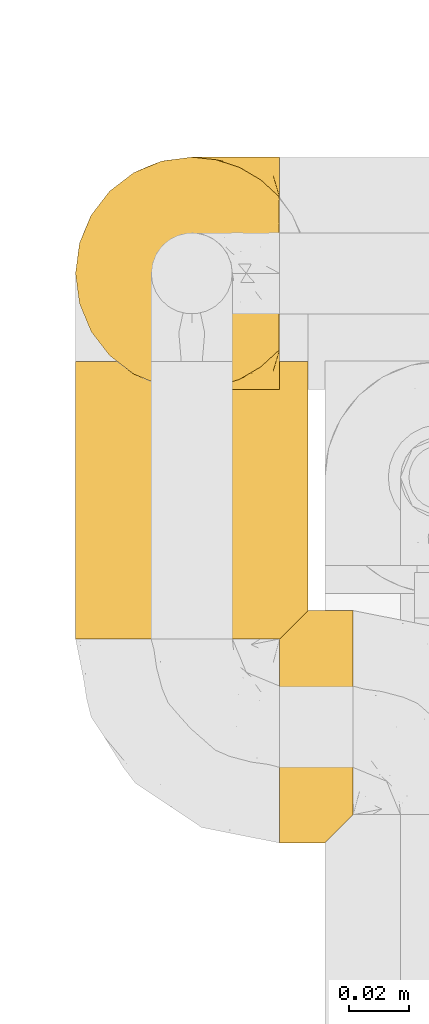
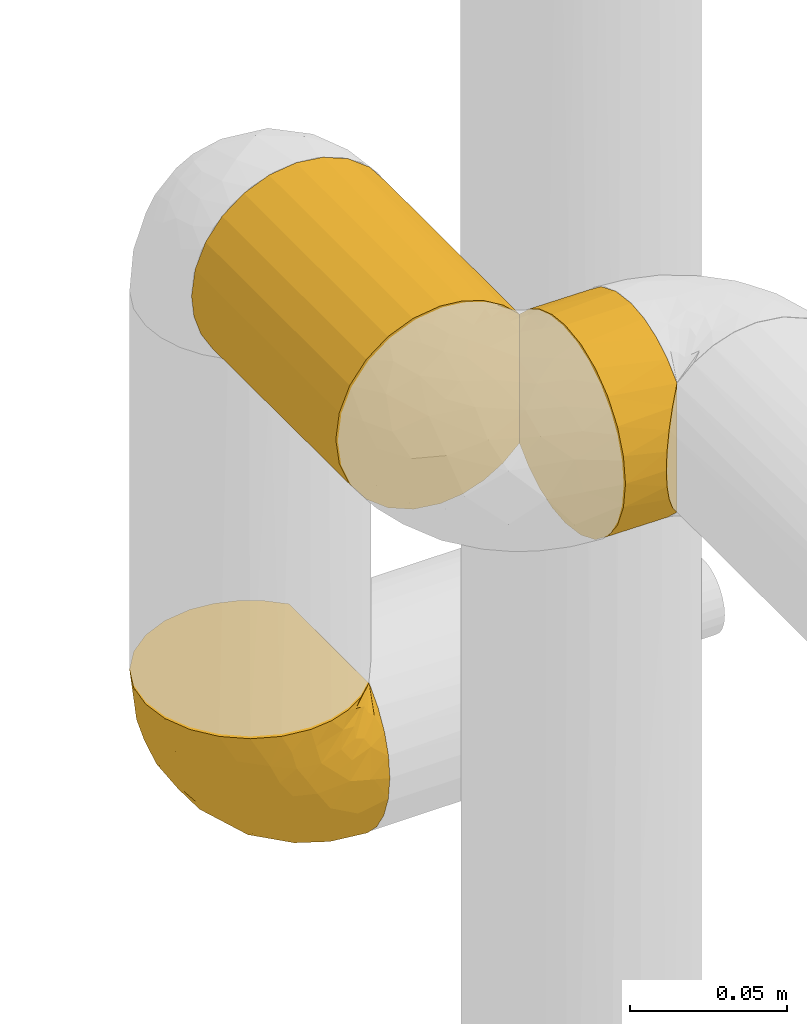
# One storey, part 82 of 827: 3 coverings.
"""IFC2X3 building model written with IfcOpenShell, lengths in millimetres."""

from ifc_helpers import new_model, entity, si_unit, converted_unit, derived_unit, direction, frame, origin, place, context, subcontext, project, spatial, faceted_brep, element, save


model = new_model("IFC2X3")

# Units and contexts
model_context = context("Model", 3, precision=0.01, world=origin(), true_north=direction((6.12303176911189e-17, 1.0)))
body_context = subcontext(model_context, "Body", "Model", "MODEL_VIEW")
ifc_project = project(units=[si_unit("LENGTHUNIT", "METRE", prefix="MILLI"), si_unit("AREAUNIT", "SQUARE_METRE"), si_unit("VOLUMEUNIT", "CUBIC_METRE"), converted_unit("PLANEANGLEUNIT", "DEGREE", entity("IfcRatioMeasure", 0.0174532925199433), si_unit("PLANEANGLEUNIT", "RADIAN"), dimensions=[0, 0, 0, 0, 0, 0, 0]), si_unit("MASSUNIT", "GRAM", prefix="KILO"), derived_unit("MASSDENSITYUNIT", [(si_unit("MASSUNIT", "GRAM", prefix="KILO"), 1), (si_unit("LENGTHUNIT", "METRE"), -3)]), derived_unit("MOMENTOFINERTIAUNIT", [(si_unit("LENGTHUNIT", "METRE"), 4)]), si_unit("TIMEUNIT", "SECOND"), si_unit("FREQUENCYUNIT", "HERTZ"), si_unit("THERMODYNAMICTEMPERATUREUNIT", "DEGREE_CELSIUS"), derived_unit("THERMALTRANSMITTANCEUNIT", [(si_unit("MASSUNIT", "GRAM", prefix="KILO"), 1), (si_unit("THERMODYNAMICTEMPERATUREUNIT", "KELVIN"), -1), (si_unit("TIMEUNIT", "SECOND"), -3)]), derived_unit("VOLUMETRICFLOWRATEUNIT", [(si_unit("LENGTHUNIT", "METRE"), 3), (si_unit("TIMEUNIT", "SECOND"), -1)]), derived_unit("MASSFLOWRATEUNIT", [(si_unit("MASSUNIT", "GRAM", prefix="KILO"), 1), (si_unit("TIMEUNIT", "SECOND"), -1)]), derived_unit("ROTATIONALFREQUENCYUNIT", [(si_unit("TIMEUNIT", "SECOND"), -1)]), si_unit("ELECTRICCURRENTUNIT", "AMPERE"), si_unit("ELECTRICVOLTAGEUNIT", "VOLT"), si_unit("POWERUNIT", "WATT"), si_unit("FORCEUNIT", "NEWTON", prefix="KILO"), si_unit("ILLUMINANCEUNIT", "LUX"), si_unit("LUMINOUSFLUXUNIT", "LUMEN"), si_unit("LUMINOUSINTENSITYUNIT", "CANDELA"), derived_unit("USERDEFINED", [(si_unit("MASSUNIT", "GRAM", prefix="KILO"), -1), (si_unit("LENGTHUNIT", "METRE"), -2), (si_unit("TIMEUNIT", "SECOND"), 3), (si_unit("LUMINOUSFLUXUNIT", "LUMEN"), 1)]), derived_unit("LINEARVELOCITYUNIT", [(si_unit("LENGTHUNIT", "METRE"), 1), (si_unit("TIMEUNIT", "SECOND"), -1)]), si_unit("PRESSUREUNIT", "PASCAL"), derived_unit("USERDEFINED", [(si_unit("LENGTHUNIT", "METRE"), -2), (si_unit("MASSUNIT", "GRAM", prefix="KILO"), 1), (si_unit("TIMEUNIT", "SECOND"), -2)]), derived_unit("LINEARFORCEUNIT", [(si_unit("MASSUNIT", "GRAM", prefix="KILO"), 1), (si_unit("LENGTHUNIT", "METRE"), 1), (si_unit("TIMEUNIT", "SECOND"), -2), (si_unit("LENGTHUNIT", "METRE"), -1)]), derived_unit("PLANARFORCEUNIT", [(si_unit("MASSUNIT", "GRAM", prefix="KILO"), 1), (si_unit("LENGTHUNIT", "METRE"), 1), (si_unit("TIMEUNIT", "SECOND"), -2), (si_unit("LENGTHUNIT", "METRE"), -2)])], contexts=[model_context])

# Site, building, storey
site_placement = place(None, origin())
site = spatial("IfcSite", under=ifc_project, at=site_placement, CompositionType="ELEMENT")
building_placement = place(site_placement, origin())
building = spatial("IfcBuilding", under=site, at=building_placement, CompositionType="ELEMENT")
storey_placement = place(building_placement, frame((0.0, 0.0, 28200.0)))
storey = spatial("IfcBuildingStorey", under=building, at=storey_placement, Name="08", CompositionType="ELEMENT", Elevation=28200.0)

# Coverings
covering_1_placement = place(storey_placement, frame((19653.72, 11848.51, 1312.9)))
element("IfcCovering", 1, at=covering_1_placement, inside=storey, Name=":ADSK_", ObjectType=":ADSK_", PredefinedType="INSULATION", context=body_context, shape_type="Brep", body=[
    faceted_brep([(69.15, 5.41, 23.36), (69.15, 9.99, 16.07), (69.15, 16.08, 9.98), (69.15, 23.37, 5.4), (69.15, 31.49, 2.56), (69.15, 40.05, 1.6), (69.15, 48.61, 2.56), (69.15, 56.73, 5.41), (69.15, 64.02, 9.99), (69.15, 70.11, 16.08), (69.15, 74.69, 23.37), (69.15, 77.53, 31.49), (69.15, 78.5, 40.05), (69.15, 77.63, 48.15), (69.15, 75.08, 55.88), (69.15, 70.97, 62.9), (69.15, 65.47, 68.89), (69.15, 63.27, 68.89), (69.15, 61.53, 68.89), (69.15, 59.57, 68.89), (69.15, 57.6, 68.89), (69.15, 55.63, 68.89), (69.15, 53.67, 68.89), (69.15, 51.7, 68.89), (69.15, 49.73, 68.89), (69.15, 47.54, 68.89), (69.15, 45.34, 68.89), (69.15, 43.15, 68.89), (69.15, 40.96, 68.89), (69.15, 38.76, 68.89), (69.15, 36.57, 68.89), (69.15, 34.37, 68.89), (69.15, 32.18, 68.89), (69.15, 29.98, 68.89), (69.15, 27.79, 68.89), (69.15, 25.6, 68.89), (69.15, 23.4, 68.89), (69.15, 21.21, 68.89), (69.15, 19.01, 68.89), (69.15, 16.82, 68.89), (69.15, 14.62, 68.89), (69.15, 9.12, 62.89), (69.15, 5.0, 55.86), (69.15, 2.46, 48.13), (69.15, 1.6, 40.05), (69.15, 2.56, 31.49), (68.89, 65.47, 69.15), (62.89, 70.97, 69.15), (55.87, 75.09, 69.15), (48.14, 77.63, 69.15), (40.05, 78.5, 69.15), (30.09, 77.19, 69.15), (20.82, 73.34, 69.15), (12.86, 67.23, 69.15), (6.75, 59.27, 69.15), (2.91, 50.0, 69.15), (1.6, 40.05, 69.15), (2.91, 30.09, 69.15), (6.75, 20.82, 69.15), (12.86, 12.86, 69.15), (20.82, 6.75, 69.15), (30.09, 2.91, 69.15), (40.05, 1.6, 69.15), (48.14, 2.46, 69.15), (55.87, 5.0, 69.15), (62.89, 9.12, 69.15), (68.89, 14.62, 69.15), (68.89, 16.82, 69.15), (68.89, 17.8, 69.15), (68.89, 19.39, 69.15), (68.89, 20.98, 69.15), (68.89, 22.57, 69.15), (68.89, 24.16, 69.15), (68.89, 25.75, 69.15), (68.89, 27.33, 69.15), (68.89, 28.92, 69.15), (68.89, 30.51, 69.15), (68.89, 32.1, 69.15), (68.89, 33.69, 69.15), (68.89, 35.28, 69.15), (68.89, 36.87, 69.15), (68.89, 38.46, 69.15), (68.89, 40.05, 69.15), (68.89, 41.63, 69.15), (68.89, 43.22, 69.15), (68.89, 44.81, 69.15), (68.89, 46.4, 69.15), (68.89, 47.99, 69.15), (68.89, 49.58, 69.15), (68.89, 51.17, 69.15), (68.89, 52.76, 69.15), (68.89, 54.72, 69.15), (68.89, 56.69, 69.15), (68.89, 58.88, 69.15), (68.89, 61.08, 69.15), (68.89, 63.27, 69.15), (68.97, 37.77, 68.96), (68.96, 36.07, 68.97), (68.97, 32.96, 68.97), (68.97, 31.36, 68.97), (68.98, 56.52, 68.95), (68.97, 54.96, 68.96), (68.96, 18.75, 68.98), (68.96, 58.07, 68.97), (68.96, 50.37, 68.97), (68.96, 23.36, 68.98), (68.96, 24.95, 68.97), (68.96, 42.43, 68.97), (69.0, 15.97, 68.94), (68.96, 51.96, 68.98), (68.96, 53.47, 68.98), (68.97, 48.63, 68.96), (68.96, 63.93, 68.97), (68.96, 40.93, 68.98), (68.96, 29.72, 68.98), (68.97, 62.4, 68.97), (68.97, 60.92, 68.96), (68.97, 17.31, 68.97), (68.96, 21.74, 68.97), (68.96, 34.56, 68.98), (68.97, 20.18, 68.96), (68.97, 14.62, 68.97), (69.02, 14.62, 68.94), (69.08, 14.62, 68.92), (68.97, 65.47, 68.97), (68.94, 65.47, 69.02), (68.92, 65.47, 69.08), (68.96, 59.5, 68.98), (68.96, 47.1, 68.97), (68.95, 45.61, 68.98), (68.96, 28.18, 68.97), (68.92, 14.62, 69.08), (68.94, 14.62, 69.02), (68.98, 26.61, 68.96), (69.08, 65.47, 68.92), (69.02, 65.47, 68.94), (68.96, 39.32, 68.97), (68.97, 44.12, 68.96), (61.33, 72.26, 67.02), (53.1, 76.57, 63.33), (63.33, 71.77, 64.61), (49.27, 78.5, 49.27), (55.53, 77.9, 51.4), (54.6, 78.5, 43.94), (41.99, 78.5, 61.87), (57.07, 75.52, 61.54), (57.95, 76.13, 57.95), (51.56, 77.81, 56.12), (41.58, 78.5, 63.4), (61.7, 72.4, 65.41), (63.33, 76.56, 53.1), (65.0, 71.77, 63.04), (67.02, 72.25, 61.33), (61.87, 78.5, 41.99), (43.94, 78.5, 54.6), (61.21, 75.75, 56.6), (63.4, 78.5, 41.58), (33.11, 50.46, 13.72), (52.82, 52.75, 5.82), (43.3, 40.05, 6.74), (33.73, 77.7, 58.82), (36.52, 77.66, 51.58), (24.87, 71.02, 42.09), (14.17, 63.45, 46.12), (18.43, 70.55, 55.56), (28.67, 75.57, 52.38), (26.0, 75.57, 61.54), (49.25, 72.61, 23.76), (59.72, 72.61, 20.5), (55.1, 67.24, 14.64), (44.72, 77.74, 41.77), (34.15, 57.43, 16.28), (5.25, 47.19, 49.4), (6.75, 54.76, 52.34), (55.54, 40.05, 4.3), (10.47, 63.45, 58.67), (25.49, 60.1, 25.26), (35.53, 63.72, 20.17), (48.22, 76.83, 34.7), (58.71, 76.34, 28.67), (57.42, 60.51, 8.62), (34.84, 72.59, 33.37), (36.87, 76.05, 41.35), (45.01, 66.15, 17.15), (44.4, 60.51, 12.68), (23.96, 51.88, 21.47), (11.2, 55.34, 41.11), (10.56, 48.67, 37.53), (16.81, 53.89, 30.64), (17.38, 46.73, 26.66), (21.38, 40.05, 21.38), (32.34, 40.05, 14.06), (4.3, 40.05, 55.54), (20.65, 63.95, 35.17), (29.66, 67.24, 29.04), (39.6, 69.62, 24.34), (42.55, 73.6, 29.33), (6.74, 40.05, 43.3), (14.06, 40.05, 32.34), (26.84, 4.52, 57.75), (5.28, 32.72, 49.41), (18.52, 27.18, 27.85), (33.13, 29.63, 13.7), (55.1, 12.86, 14.63), (57.43, 19.59, 8.61), (20.72, 9.54, 48.85), (11.46, 16.64, 54.13), (17.69, 17.48, 37.84), (49.26, 7.49, 23.75), (59.73, 7.49, 20.49), (58.71, 3.75, 28.66), (29.72, 20.75, 20.83), (35.35, 2.33, 55.15), (43.94, 1.6, 54.6), (41.99, 1.6, 61.87), (63.4, 1.6, 41.58), (4.93, 26.94, 57.58), (17.46, 9.54, 59.91), (10.94, 31.21, 36.94), (8.92, 25.33, 45.72), (52.83, 27.35, 5.82), (29.34, 8.17, 37.91), (30.26, 4.3, 50.18), (44.4, 19.59, 12.67), (39.06, 2.23, 49.29), (43.06, 2.45, 42.64), (54.6, 1.6, 43.94), (49.27, 1.6, 49.27), (42.69, 12.86, 19.45), (48.2, 3.27, 34.7), (61.87, 1.6, 41.99), (33.44, 2.29, 62.29), (29.67, 12.86, 29.01), (38.5, 6.89, 31.47), (23.35, 12.43, 37.18), (34.97, 4.1, 43.45), (53.1, 3.53, 63.33), (59.68, 6.88, 67.23), (62.19, 8.16, 66.07), (64.11, 9.02, 65.22), (57.97, 5.0, 61.99), (57.95, 3.96, 57.95), (63.33, 3.52, 53.09), (51.77, 2.4, 56.84), (67.02, 7.83, 61.33), (64.98, 8.32, 63.06), (55.53, 2.19, 51.41), (61.22, 4.34, 56.61)], [[[0, 1, 2, 3, 4, 5, 6, 7, 8, 9, 10, 11, 12, 13, 14, 15, 16, 17, 18, 19, 20, 21, 22, 23, 24, 25, 26, 27, 28, 29, 30, 31, 32, 33, 34, 35, 36, 37, 38, 39, 40, 41, 42, 43, 44, 45]], [[46, 47, 48, 49, 50, 51, 52, 53, 54, 55, 56, 57, 58, 59, 60, 61, 62, 63, 64, 65, 66, 67, 68, 69, 70, 71, 72, 73, 74, 75, 76, 77, 78, 79, 80, 81, 82, 83, 84, 85, 86, 87, 88, 89, 90, 91, 92, 93, 94, 95]], [[96, 97, 30]], [[98, 77, 99]], [[100, 101, 21]], [[69, 68, 102]], [[20, 19, 103]], [[24, 23, 104]], [[20, 103, 100]], [[72, 105, 106]], [[84, 83, 107]], [[89, 88, 104]], [[108, 67, 66]], [[109, 110, 90]], [[111, 25, 24]], [[112, 17, 16]], [[82, 113, 83]], [[109, 23, 22]], [[114, 76, 75]], [[105, 36, 106]], [[104, 111, 24]], [[18, 115, 116]], [[97, 96, 80]], [[67, 108, 117]], [[105, 71, 118]], [[31, 97, 119]], [[102, 120, 69]], [[108, 121, 122, 123, 40]], [[112, 95, 115]], [[17, 115, 18]], [[94, 116, 115]], [[117, 68, 67]], [[38, 117, 39]], [[112, 124, 125, 126, 46]], [[17, 112, 115]], [[70, 120, 118]], [[39, 117, 108]], [[120, 38, 37]], [[120, 37, 118]], [[120, 70, 69]], [[116, 94, 127]], [[128, 86, 129]], [[117, 38, 102]], [[74, 130, 75]], [[99, 33, 32]], [[115, 95, 94]], [[39, 108, 40]], [[108, 66, 131, 132, 121]], [[105, 72, 71]], [[118, 37, 36]], [[71, 70, 118]], [[35, 106, 36]], [[36, 105, 118]], [[35, 133, 106]], [[74, 73, 133]], [[106, 133, 73]], [[99, 114, 33]], [[133, 35, 34]], [[73, 72, 106]], [[95, 112, 46]], [[112, 16, 134, 135, 124]], [[130, 114, 75]], [[99, 76, 114]], [[114, 130, 33]], [[34, 33, 130]], [[78, 77, 98]], [[98, 119, 78]], [[130, 133, 34]], [[133, 130, 74]], [[79, 97, 80]], [[98, 99, 32]], [[98, 32, 31]], [[77, 76, 99]], [[97, 79, 119]], [[136, 96, 29]], [[30, 97, 31]], [[136, 29, 28]], [[81, 80, 96]], [[29, 96, 30]], [[31, 119, 98]], [[119, 79, 78]], [[96, 136, 81]], [[82, 81, 136]], [[113, 107, 83]], [[84, 107, 137]], [[107, 27, 137]], [[113, 28, 107]], [[27, 107, 28]], [[85, 84, 137]], [[137, 27, 26]], [[113, 136, 28]], [[136, 113, 82]], [[109, 89, 104]], [[86, 85, 129]], [[89, 109, 90]], [[111, 87, 128]], [[26, 129, 137]], [[88, 111, 104]], [[25, 111, 128]], [[22, 110, 109]], [[23, 109, 104]], [[110, 91, 90]], [[100, 92, 101]], [[110, 22, 101]], [[91, 110, 101]], [[116, 19, 18]], [[111, 88, 87]], [[127, 103, 19]], [[25, 128, 26]], [[86, 128, 87]], [[128, 129, 26]], [[137, 129, 85]], [[120, 102, 38]], [[117, 102, 68]], [[91, 101, 92]], [[21, 101, 22]], [[93, 92, 103]], [[100, 21, 20]], [[100, 103, 92]], [[127, 93, 103]], [[93, 127, 94]], [[116, 127, 19]], [[126, 138, 47]], [[48, 138, 139]], [[140, 125, 124]], [[141, 142, 143]], [[144, 49, 139]], [[145, 140, 146]], [[48, 139, 49]], [[139, 145, 147]], [[49, 144, 148, 50]], [[126, 125, 149]], [[14, 13, 150]], [[151, 146, 140]], [[149, 140, 145]], [[152, 151, 135]], [[152, 14, 150]], [[16, 15, 134]], [[13, 153, 150]], [[124, 151, 140]], [[141, 147, 142]], [[14, 152, 15]], [[15, 152, 134]], [[47, 46, 126]], [[139, 154, 144]], [[138, 48, 47]], [[125, 140, 149]], [[135, 134, 152]], [[146, 155, 142]], [[145, 146, 147]], [[149, 139, 138]], [[147, 141, 154]], [[147, 146, 142]], [[139, 147, 154]], [[139, 149, 145]], [[149, 138, 126]], [[155, 146, 151]], [[150, 143, 142]], [[152, 155, 151]], [[150, 142, 155]], [[13, 12, 156, 153]], [[153, 143, 150]], [[152, 150, 155]], [[151, 124, 135]], [[157, 158, 159]], [[160, 154, 161]], [[162, 163, 164]], [[165, 166, 160]], [[167, 168, 169]], [[141, 170, 161]], [[156, 12, 11]], [[158, 157, 171]], [[172, 55, 173]], [[158, 6, 174]], [[175, 54, 53]], [[52, 166, 164]], [[52, 164, 53]], [[54, 175, 173]], [[166, 52, 51]], [[176, 177, 171]], [[178, 143, 179]], [[156, 11, 179]], [[8, 7, 180]], [[169, 9, 8]], [[179, 143, 153, 156]], [[179, 11, 10]], [[168, 179, 10]], [[181, 162, 182]], [[179, 167, 178]], [[183, 184, 177]], [[183, 169, 184]], [[176, 171, 185]], [[172, 186, 187]], [[158, 7, 6]], [[159, 158, 174]], [[184, 180, 158]], [[54, 173, 55]], [[180, 169, 8]], [[188, 189, 187]], [[9, 168, 10]], [[186, 188, 187]], [[190, 157, 159, 191]], [[55, 172, 192]], [[176, 193, 194]], [[161, 170, 182]], [[162, 164, 165]], [[175, 164, 163]], [[51, 50, 148]], [[167, 195, 196]], [[178, 182, 170]], [[6, 5, 174]], [[158, 180, 7]], [[169, 180, 184]], [[169, 168, 9]], [[179, 168, 167]], [[182, 162, 165]], [[162, 194, 193]], [[161, 165, 160]], [[195, 181, 196]], [[192, 172, 197]], [[192, 56, 55]], [[189, 190, 198]], [[198, 197, 187]], [[172, 187, 197]], [[185, 189, 188]], [[198, 187, 189]], [[186, 172, 173]], [[173, 163, 186]], [[193, 186, 163]], [[176, 185, 188]], [[185, 157, 190]], [[188, 186, 193]], [[177, 176, 194]], [[188, 193, 176]], [[162, 193, 163]], [[195, 177, 194]], [[171, 177, 184]], [[181, 195, 194]], [[183, 167, 169]], [[162, 181, 194]], [[196, 182, 178]], [[158, 171, 184]], [[171, 157, 185]], [[177, 195, 183]], [[167, 183, 195]], [[182, 196, 181]], [[178, 170, 143]], [[178, 167, 196]], [[164, 175, 53]], [[173, 175, 163]], [[160, 51, 148]], [[164, 166, 165]], [[51, 160, 166]], [[160, 148, 144, 154]], [[141, 161, 154]], [[182, 165, 161]], [[190, 189, 185]], [[143, 170, 141]], [[60, 199, 61]], [[197, 200, 192]], [[201, 190, 202]], [[200, 57, 192]], [[203, 204, 2]], [[205, 206, 207]], [[208, 209, 210]], [[211, 207, 201]], [[212, 213, 214]], [[45, 215, 210]], [[216, 206, 58]], [[45, 44, 215]], [[59, 217, 60]], [[60, 217, 199]], [[0, 45, 210]], [[218, 201, 219]], [[202, 159, 220]], [[205, 221, 222]], [[223, 204, 203]], [[1, 203, 2]], [[57, 200, 216]], [[220, 3, 204]], [[220, 174, 4]], [[1, 0, 209]], [[212, 224, 213]], [[225, 226, 227]], [[228, 223, 203]], [[208, 210, 229]], [[210, 226, 229]], [[3, 220, 4]], [[58, 206, 59]], [[209, 203, 1]], [[202, 220, 223]], [[228, 203, 208]], [[202, 211, 201]], [[3, 2, 204]], [[202, 190, 191, 159]], [[210, 215, 230, 226]], [[199, 212, 231]], [[232, 233, 221]], [[233, 208, 229]], [[207, 206, 219]], [[217, 206, 205]], [[227, 224, 225]], [[233, 232, 228]], [[201, 207, 219]], [[234, 232, 221]], [[218, 219, 200]], [[202, 223, 211]], [[174, 220, 159]], [[174, 5, 4]], [[61, 231, 62]], [[220, 204, 223]], [[210, 209, 0]], [[203, 209, 208]], [[225, 233, 229]], [[224, 227, 213]], [[221, 233, 235]], [[57, 56, 192]], [[198, 218, 197]], [[200, 219, 216]], [[201, 198, 190]], [[197, 218, 200]], [[198, 201, 218]], [[206, 216, 219]], [[58, 57, 216]], [[231, 212, 214]], [[222, 212, 199]], [[228, 211, 223]], [[207, 211, 232]], [[62, 231, 214]], [[199, 231, 61]], [[233, 228, 208]], [[211, 228, 232]], [[222, 221, 235]], [[234, 205, 207]], [[206, 217, 59]], [[199, 217, 205]], [[205, 222, 199]], [[224, 222, 235]], [[222, 224, 212]], [[224, 235, 225]], [[233, 225, 235]], [[226, 225, 229]], [[205, 234, 221]], [[207, 232, 234]], [[63, 214, 236]], [[214, 213, 236]], [[214, 63, 62]], [[237, 236, 238]], [[238, 132, 131]], [[236, 237, 64]], [[239, 240, 241]], [[63, 236, 64]], [[131, 66, 65]], [[237, 131, 65]], [[242, 230, 43]], [[237, 65, 64]], [[239, 121, 132]], [[42, 242, 43]], [[241, 240, 243]], [[41, 123, 244]], [[43, 230, 215, 44]], [[244, 122, 245]], [[227, 246, 243]], [[245, 241, 247]], [[121, 239, 245]], [[41, 40, 123]], [[132, 238, 239]], [[244, 42, 41]], [[131, 237, 238]], [[240, 239, 238]], [[245, 239, 241]], [[247, 241, 246]], [[247, 244, 245]], [[238, 236, 240]], [[243, 236, 213]], [[236, 243, 240]], [[246, 241, 243]], [[243, 213, 227]], [[226, 242, 246]], [[227, 226, 246]], [[246, 242, 247]], [[244, 247, 242]], [[242, 226, 230]], [[42, 244, 242]], [[122, 244, 123]], [[122, 121, 245]]]),
])
covering_2_placement = place(storey_placement, frame((19653.77, 11766.06, 1518.17)))
element("IfcCovering", 2, at=covering_2_placement, inside=storey, Name=":ADSK_", ObjectType=":ADSK_", PredefinedType="INSULATION", context=body_context, shape_type="Brep", body=[
    faceted_brep([(20.8, 1.6, 6.74), (30.06, 1.6, 2.9), (40.0, 1.6, 1.6), (48.2, 1.6, 2.48), (56.01, 1.6, 5.09), (63.08, 1.6, 9.31), (69.1, 1.6, 14.94), (69.1, 1.6, 65.05), (63.08, 1.6, 70.68), (56.01, 1.6, 74.9), (48.2, 1.6, 77.51), (40.0, 1.6, 78.4), (30.06, 1.6, 77.09), (20.8, 1.6, 73.25), (12.84, 1.6, 67.15), (6.74, 1.6, 59.2), (2.9, 1.6, 49.93), (1.6, 1.6, 40.0), (2.9, 1.6, 30.06), (6.74, 1.6, 20.8), (12.84, 1.6, 12.84), (14.94, 93.4, 10.9), (9.31, 93.4, 16.91), (5.09, 93.4, 23.98), (2.48, 93.4, 31.79), (1.6, 93.4, 40.0), (2.9, 93.4, 49.93), (6.74, 93.4, 59.2), (12.84, 93.4, 67.15), (20.8, 93.4, 73.25), (30.06, 93.4, 77.09), (40.0, 93.4, 78.4), (49.93, 93.4, 77.09), (59.2, 93.4, 73.25), (67.15, 93.4, 67.15), (73.25, 93.4, 59.2), (77.09, 93.4, 49.93), (78.4, 93.4, 40.0), (77.51, 93.4, 31.79), (74.9, 93.4, 23.98), (70.68, 93.4, 16.91), (65.05, 93.4, 10.9), (20.48, 89.42, 6.92), (26.63, 86.5, 4.0), (33.21, 84.7, 2.2), (40.0, 84.1, 1.6), (46.78, 84.7, 2.2), (53.36, 86.5, 4.0), (59.51, 89.42, 6.92), (73.07, 5.57, 20.48), (76.0, 8.5, 26.63), (77.79, 10.29, 33.21), (78.4, 10.9, 40.0), (77.79, 10.29, 46.78), (76.0, 8.5, 53.36), (73.07, 5.57, 59.51)], [[[0, 1, 2, 3, 4, 5, 6, 7, 8, 9, 10, 11, 12, 13, 14, 15, 16, 17, 18, 19, 20]], [[21, 22, 23, 24, 25, 26, 27, 28, 29, 30, 31, 32, 33, 34, 35, 36, 37, 38, 39, 40, 41]], [[25, 24, 17]], [[23, 22, 19]], [[24, 23, 18]], [[18, 17, 24]], [[19, 18, 23]], [[22, 20, 19]], [[22, 21, 20]], [[21, 42, 0]], [[43, 44, 1]], [[42, 43, 0]], [[0, 43, 1]], [[2, 1, 44]], [[45, 2, 44]], [[21, 0, 20]], [[46, 47, 3]], [[48, 41, 5]], [[47, 48, 4]], [[45, 46, 2]], [[3, 2, 46]], [[47, 4, 3]], [[48, 5, 4]], [[41, 6, 5]], [[49, 40, 39]], [[50, 39, 38]], [[51, 38, 37]], [[49, 6, 40]], [[51, 50, 38]], [[52, 51, 37]], [[49, 39, 50]], [[40, 6, 41]], [[53, 52, 37]], [[53, 37, 36]], [[54, 36, 35]], [[54, 53, 36]], [[7, 55, 35]], [[54, 35, 55]], [[35, 34, 7]], [[8, 34, 33]], [[9, 33, 32]], [[10, 32, 31]], [[8, 33, 9]], [[9, 32, 10]], [[31, 11, 10]], [[34, 8, 7]], [[12, 11, 31, 30]], [[13, 12, 30, 29]], [[29, 28, 14, 13]], [[16, 15, 27, 26]], [[17, 16, 26, 25]], [[28, 27, 15, 14]], [[6, 49, 50, 51, 52, 53, 54, 55, 7]], [[47, 46, 45, 44, 43, 42, 21, 41, 48]]]),
])
covering_3_placement = place(storey_placement, frame((19721.27, 11698.56, 1518.17)))
element("IfcCovering", 3, at=covering_3_placement, inside=storey, Name=":ADSK_", ObjectType=":ADSK_", PredefinedType="INSULATION", context=body_context, shape_type="Brep", body=[
    faceted_brep([(1.6, 20.8, 6.74), (1.6, 12.84, 12.84), (1.6, 6.74, 20.8), (1.6, 2.9, 30.06), (1.6, 1.6, 40.0), (1.6, 2.9, 49.93), (1.6, 6.74, 59.2), (1.6, 12.84, 67.15), (1.6, 20.8, 73.25), (1.6, 30.06, 77.09), (1.6, 40.0, 78.4), (1.6, 48.2, 77.51), (1.6, 56.01, 74.9), (1.6, 63.08, 70.68), (1.6, 69.1, 65.05), (1.6, 69.1, 14.94), (1.6, 63.08, 9.31), (1.6, 56.01, 5.09), (1.6, 48.2, 2.48), (1.6, 40.0, 1.6), (1.6, 30.06, 2.9), (25.9, 10.9, 65.05), (25.9, 10.9, 14.94), (25.9, 16.91, 9.31), (25.9, 23.98, 5.09), (25.9, 31.79, 2.48), (25.9, 40.0, 1.6), (25.9, 49.93, 2.9), (25.9, 59.2, 6.74), (25.9, 67.15, 12.84), (25.9, 73.25, 20.8), (25.9, 77.09, 30.06), (25.9, 78.4, 40.0), (25.9, 77.09, 49.93), (25.9, 73.25, 59.2), (25.9, 67.15, 67.15), (25.9, 59.2, 73.25), (25.9, 49.93, 77.09), (25.9, 40.0, 78.4), (25.9, 31.79, 77.51), (25.9, 23.98, 74.9), (25.9, 16.91, 70.68), (10.29, 77.79, 33.21), (10.9, 78.4, 40.0), (8.5, 76.0, 26.63), (5.57, 73.07, 20.48), (21.92, 6.92, 20.48), (19.0, 4.0, 26.63), (17.2, 2.2, 33.21), (16.6, 1.6, 40.0), (17.2, 2.2, 46.78), (19.0, 4.0, 53.36), (21.92, 6.92, 59.51), (8.5, 76.0, 53.36), (10.29, 77.79, 46.78), (5.57, 73.07, 59.51)], [[[0, 1, 2, 3, 4, 5, 6, 7, 8, 9, 10, 11, 12, 13, 14, 15, 16, 17, 18, 19, 20]], [[21, 22, 23, 24, 25, 26, 27, 28, 29, 30, 31, 32, 33, 34, 35, 36, 37, 38, 39, 40, 41]], [[42, 43, 32]], [[42, 32, 31]], [[44, 31, 30]], [[44, 42, 31]], [[29, 15, 45]], [[44, 30, 45]], [[45, 30, 29]], [[29, 28, 16]], [[27, 26, 18]], [[28, 27, 17]], [[17, 16, 28]], [[19, 18, 26]], [[17, 27, 18]], [[29, 16, 15]], [[19, 26, 25]], [[25, 24, 20]], [[23, 0, 24]], [[19, 25, 20]], [[0, 20, 24]], [[1, 0, 23]], [[23, 22, 1]], [[46, 2, 1]], [[47, 48, 3]], [[46, 47, 2]], [[2, 47, 3]], [[4, 3, 48]], [[49, 4, 48]], [[46, 1, 22]], [[50, 51, 5]], [[6, 52, 7]], [[51, 52, 6]], [[49, 50, 4]], [[4, 50, 5]], [[51, 6, 5]], [[52, 21, 7]], [[8, 41, 40]], [[40, 39, 9]], [[38, 10, 39]], [[7, 41, 8]], [[9, 8, 40]], [[10, 9, 39]], [[41, 7, 21]], [[11, 38, 37]], [[37, 36, 12]], [[35, 13, 36]], [[10, 38, 11]], [[12, 11, 37]], [[13, 12, 36]], [[35, 14, 13]], [[53, 34, 33]], [[33, 32, 54]], [[43, 54, 32]], [[14, 35, 55]], [[54, 53, 33]], [[55, 34, 53]], [[55, 35, 34]], [[14, 55, 53, 54, 43, 42, 44, 45, 15]], [[49, 48, 47, 46, 22, 21, 52, 51, 50]]]),
])

save(model, "model.ifc")
